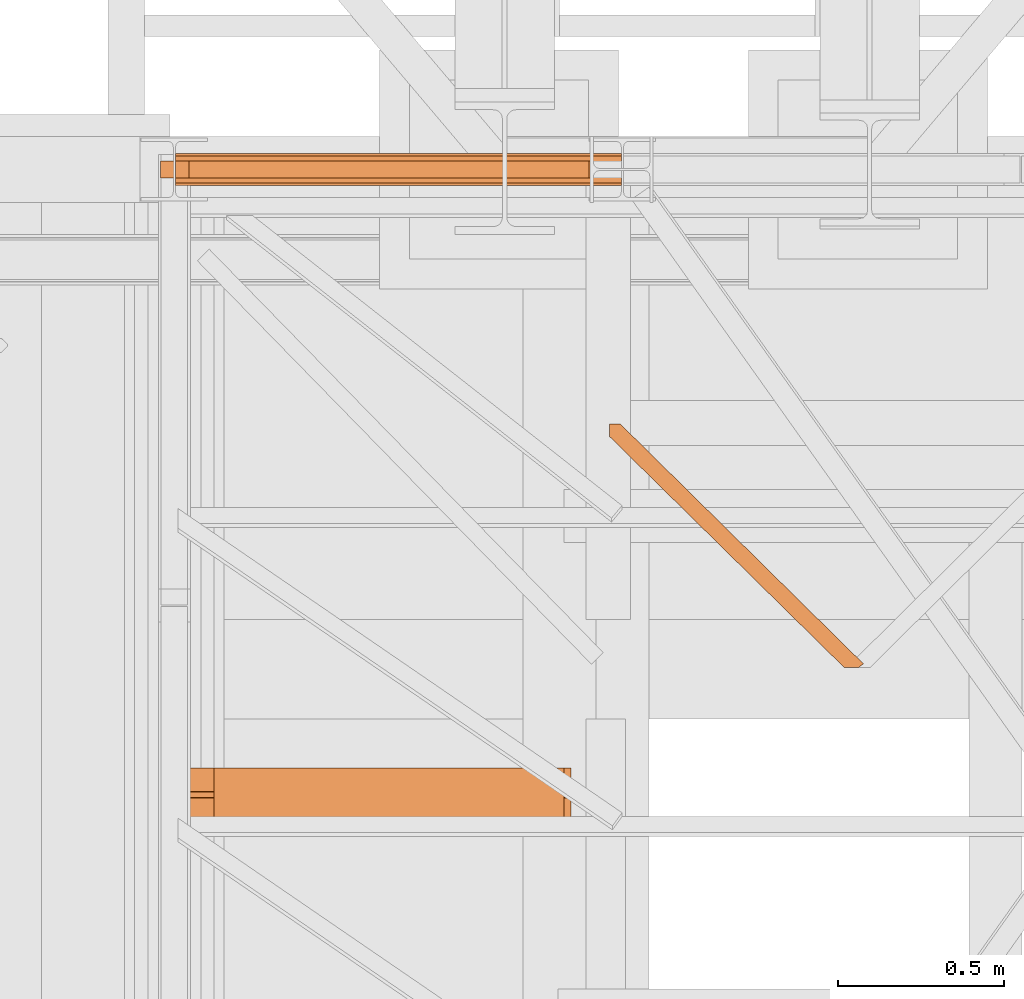
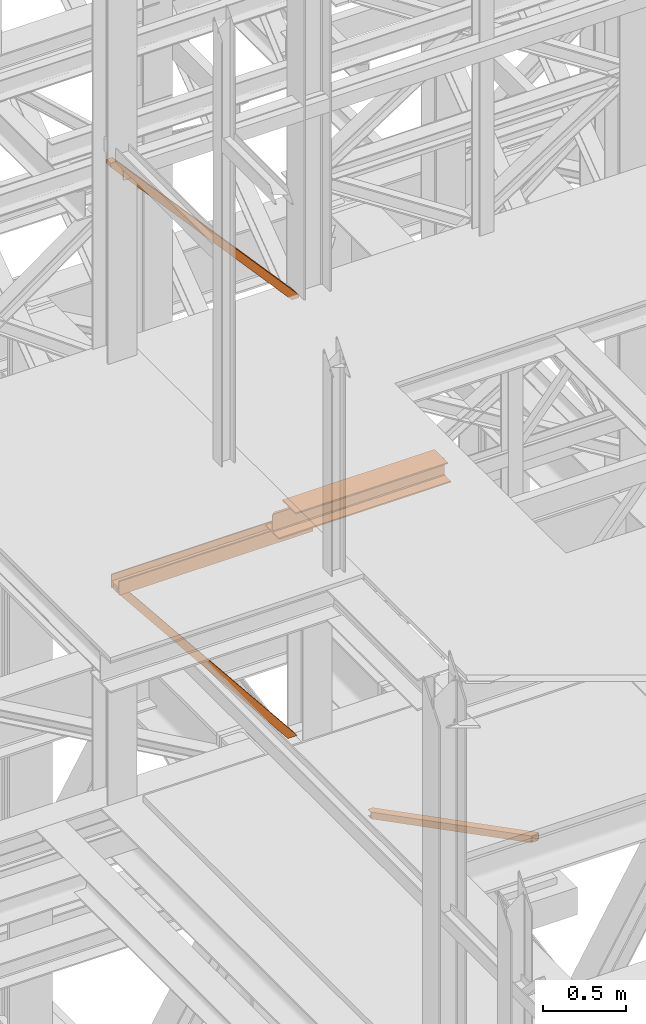
# One storey, part 35 of 208: 5 proxies.
"""IFC2X3 building model written with IfcOpenShell, lengths in millimetres."""

from ifc_helpers import new_model, entity, si_unit, converted_unit, frame, origin, origin_with_axes, place, context, subcontext, project, spatial, faceted_brep, element, save


model = new_model("IFC2X3")

# Units and contexts
model_context = context("Model", 3, precision=1e-05, world=origin())
plan_context = context("Plan", 3, precision=1e-05, world=origin())
body_context = subcontext(model_context, "Body", "Model", "MODEL_VIEW")
ifc_project = project(units=[si_unit("LENGTHUNIT", "METRE", prefix="MILLI"), converted_unit("PLANEANGLEUNIT", "DEGREE", entity("IfcPlaneAngleMeasure", 0.0174532925199433), si_unit("PLANEANGLEUNIT", "RADIAN"), dimensions=[0, 0, 0, 0, 0, 0, 0]), si_unit("AREAUNIT", "SQUARE_METRE"), si_unit("VOLUMEUNIT", "CUBIC_METRE")], contexts=[model_context, plan_context])

# Building, storey
building_placement = place(None, origin())
building = spatial("IfcBuilding", under=ifc_project, at=building_placement, CompositionType="COMPLEX")
storey_placement = place(building_placement, origin_with_axes())
storey = spatial("IfcBuildingStorey", under=building, at=storey_placement, Name="Geschoss", CompositionType="ELEMENT")

# Proxies
proxy_1_placement = place(storey_placement, frame((1156.503995494019, -17287.57439069042, 8484.990002086157), z_axis=(0.0, 0.0, 1.0), x_axis=(1.0, 0.0, 0.0)))
element("IfcBuildingElementProxy", 1, at=proxy_1_placement, inside=storey, context=body_context, shape_type="Brep", body=[
    faceted_brep([(1304.510962990662, 0.01000000000567525, 19.5301319327009), (40.73573083418137, 0.01000000000567525, 1439.925067016873), (40.73573083418137, 50.01000074506374, 1439.925067016873), (1304.510962990664, 50.01000074506374, 19.5301319327009), (1304.510962990664, 50.01000074506374, 19.5301319327009), (40.73573083418137, 50.01000074506374, 1439.925067016873), (0.009999999999990905, 50.01000074506374, 1438.117904338133), (1.300874909247568, 50.01000074506374, 1409.02709546241), (1254.95284377165, 50.0100007450601, 0.01000000000021828), (1304.510962990662, 50.0100007450601, 0.01000000000021828), (1254.95284377165, 50.0100007450601, 0.01000000000021828), (1.300874909247568, 50.01000074506374, 1409.02709546241), (1.300874909245749, 0.01000000000567525, 1409.027095462412), (1254.95284377165, 0.01000000000203727, 0.01000000000021828), (1254.95284377165, 0.01000000000203727, 0.01000000000021828), (1.300874909245749, 0.01000000000567525, 1409.027095462412), (0.009999999999990905, 0.01000000000567525, 1438.117904338133), (40.73573083418137, 0.01000000000567525, 1439.925067016873), (1304.510962990662, 0.01000000000567525, 19.5301319327009), (1304.510962990662, 0.01000000000203727, 0.01000000000021828), (40.73573083418137, 0.01000000000567525, 1439.925067016873), (0.009999999999990905, 0.01000000000567525, 1438.117904338133), (0.009999999999990905, 50.01000074506374, 1438.117904338133), (40.73573083418137, 50.01000074506374, 1439.925067016873), (0.009999999999990905, 50.01000074506374, 1438.117904338133), (0.009999999999990905, 0.01000000000567525, 1438.117904338133), (1.300874909245749, 0.01000000000567525, 1409.027095462412), (1.300874909247568, 50.01000074506374, 1409.02709546241), (1304.510962990662, 50.0100007450601, 0.01000000000021828), (1254.95284377165, 50.0100007450601, 0.01000000000021828), (1254.95284377165, 0.01000000000203727, 0.01000000000021828), (1304.510962990662, 0.01000000000203727, 0.01000000000021828), (1304.510962990664, 50.01000074506374, 19.5301319327009), (1304.510962990662, 50.0100007450601, 0.01000000000021828), (1304.510962990662, 0.01000000000203727, 0.01000000000021828), (1304.510962990662, 0.01000000000567525, 19.5301319327009)], [[[0, 1, 2, 3]], [[4, 5, 6, 7, 8, 9]], [[10, 11, 12, 13]], [[14, 15, 16, 17, 18, 19]], [[20, 21, 22, 23]], [[24, 25, 26, 27]], [[28, 29, 30, 31]], [[32, 33, 34, 35]]], orient=[[False], [False], [False], [False], [False], [False], [False], [False]]),
])
proxy_2_placement = place(storey_placement, frame((1201.504968595722, -17310.57438993344, 6759.989999254943), z_axis=(0.0, 0.0, 1.0), x_axis=(1.0, 0.0, 0.0)))
element("IfcBuildingElementProxy", 2, at=proxy_2_placement, inside=storey, context=body_context, shape_type="Brep", body=[
    faceted_brep([(0.009999999999990905, 88.0099999999984, 0.01000000000021828), (0.009999999999990905, 96.0099999999984, 0.01000000000021828), (0.009999999999990905, 96.0099999999984, 100.0100000000002), (0.009999999999990905, 88.0099999999984, 100.0100000000002), (0.009999999999990905, 88.0099999999984, 52.51000000000022), (0.009999999999990905, 8.0099999999984, 52.51000000000022), (0.009999999999990905, 8.0099999999984, 100.0100000000002), (0.009999999999990905, 0.00999999999839929, 100.0100000000002), (0.009999999999990905, 0.00999999999839929, 0.01000000000021828), (0.009999999999990905, 8.0099999999984, 0.01000000000021828), (0.009999999999990905, 8.0099999999984, 47.51000000000022), (0.009999999999990905, 88.0099999999984, 47.51000000000022), (0.009999999999990905, 96.0099999999984, 0.01000000000021828), (0.009999999999990905, 88.0099999999984, 0.01000000000021828), (1343.509999865888, 88.0099999999984, 0.01000000000021828), (1343.509999865888, 96.0099999999984, 0.01000000000021828), (0.009999999999990905, 96.0099999999984, 100.0100000000002), (0.009999999999990905, 96.0099999999984, 0.01000000000021828), (1343.509999865888, 96.0099999999984, 0.01000000000021828), (1343.509999865888, 96.0099999999984, 100.0100000000002), (0.009999999999990905, 88.0099999999984, 100.0100000000002), (0.009999999999990905, 96.0099999999984, 100.0100000000002), (1343.509999865888, 96.0099999999984, 100.0100000000002), (1343.509999865888, 88.0099999999984, 100.0100000000002), (0.009999999999990905, 88.0099999999984, 52.51000000000022), (0.009999999999990905, 88.0099999999984, 100.0100000000002), (1343.509999865888, 88.0099999999984, 100.0100000000002), (1343.509999865888, 88.0099999999984, 52.51000000000022), (0.009999999999990905, 8.0099999999984, 52.51000000000022), (0.009999999999990905, 88.0099999999984, 52.51000000000022), (1343.509999865888, 88.0099999999984, 52.51000000000022), (1343.509999865888, 8.0099999999984, 52.51000000000022), (0.009999999999990905, 8.0099999999984, 100.0100000000002), (0.009999999999990905, 8.0099999999984, 52.51000000000022), (1343.509999865888, 8.0099999999984, 52.51000000000022), (1343.509999865888, 8.0099999999984, 100.0100000000002), (0.009999999999990905, 0.00999999999839929, 100.0100000000002), (0.009999999999990905, 8.0099999999984, 100.0100000000002), (1343.509999865888, 8.0099999999984, 100.0100000000002), (1343.509999865888, 0.00999999999839929, 100.0100000000002), (0.009999999999990905, 0.00999999999839929, 0.01000000000021828), (0.009999999999990905, 0.00999999999839929, 100.0100000000002), (1343.509999865888, 0.00999999999839929, 100.0100000000002), (1343.509999865888, 0.00999999999839929, 0.01000000000021828), (0.009999999999990905, 8.0099999999984, 0.01000000000021828), (0.009999999999990905, 0.00999999999839929, 0.01000000000021828), (1343.509999865888, 0.00999999999839929, 0.01000000000021828), (1343.509999865888, 8.0099999999984, 0.01000000000021828), (0.009999999999990905, 8.0099999999984, 47.51000000000022), (0.009999999999990905, 8.0099999999984, 0.01000000000021828), (1343.509999865888, 8.0099999999984, 0.01000000000021828), (1343.509999865888, 8.0099999999984, 47.51000000000022), (0.009999999999990905, 88.0099999999984, 47.51000000000022), (0.009999999999990905, 8.0099999999984, 47.51000000000022), (1343.509999865888, 8.0099999999984, 47.51000000000022), (1343.509999865888, 88.0099999999984, 47.51000000000022), (0.009999999999990905, 88.0099999999984, 0.01000000000021828), (0.009999999999990905, 88.0099999999984, 47.51000000000022), (1343.509999865888, 88.0099999999984, 47.51000000000022), (1343.509999865888, 88.0099999999984, 0.01000000000021828), (1343.509999865888, 88.0099999999984, 0.01000000000021828), (1343.509999865888, 88.0099999999984, 47.51000000000022), (1343.509999865888, 8.0099999999984, 47.51000000000022), (1343.509999865888, 8.0099999999984, 0.01000000000021828), (1343.509999865888, 0.00999999999839929, 0.01000000000021828), (1343.509999865888, 0.00999999999839929, 100.0100000000002), (1343.509999865888, 8.0099999999984, 100.0100000000002), (1343.509999865888, 8.0099999999984, 52.51000000000022), (1343.509999865888, 88.0099999999984, 52.51000000000022), (1343.509999865888, 88.0099999999984, 100.0100000000002), (1343.509999865888, 96.0099999999984, 100.0100000000002), (1343.509999865888, 96.0099999999984, 0.01000000000021828)], [[[0, 1, 2, 3, 4, 5, 6, 7, 8, 9, 10, 11]], [[12, 13, 14, 15]], [[16, 17, 18, 19]], [[20, 21, 22, 23]], [[24, 25, 26, 27]], [[28, 29, 30, 31]], [[32, 33, 34, 35]], [[36, 37, 38, 39]], [[40, 41, 42, 43]], [[44, 45, 46, 47]], [[48, 49, 50, 51]], [[52, 53, 54, 55]], [[56, 57, 58, 59]], [[60, 61, 62, 63, 64, 65, 66, 67, 68, 69, 70, 71]]], orient=[[False], [False], [False], [False], [False], [False], [False], [False], [False], [False], [False], [False], [False], [False]]),
])
proxy_3_placement = place(storey_placement, frame((1201.504968595721, -17287.57439069042, 5284.990005364413), z_axis=(0.0, 0.0, 1.0), x_axis=(1.0, 0.0, 0.0)))
element("IfcBuildingElementProxy", 3, at=proxy_3_placement, inside=storey, context=body_context, shape_type="Brep", body=[
    faceted_brep([(1246.759998442829, 50.0100007450601, 0.01000000000112777), (1246.759998442828, 0.01000000000203727, 0.01000000000021828), (40.77580661443676, 0.01000000000567525, 1510.509994121497), (40.77580661443676, 50.01000074506374, 1510.509994121497), (1182.312723265392, 50.0100007450601, 0.01000000000112777), (1246.759998442829, 50.0100007450601, 0.01000000000112777), (40.77580661443676, 50.01000074506374, 1510.509994121497), (0.0100000000009004, 50.01000074506374, 1510.509994121497), (0.0100000000009004, 50.01000074506374, 1481.39055870329), (1182.312723265392, 0.01000000000203727, 0.01000000000112777), (1182.312723265392, 50.0100007450601, 0.01000000000112777), (0.0100000000009004, 50.01000074506374, 1481.39055870329), (0.009999999999990905, 0.01000000000567525, 1481.390558703291), (1246.759998442828, 0.01000000000203727, 0.01000000000021828), (1182.312723265392, 0.01000000000203727, 0.01000000000112777), (0.009999999999990905, 0.01000000000567525, 1481.390558703291), (0.009999999999990905, 0.01000000000567525, 1510.509994121498), (40.77580661443676, 0.01000000000567525, 1510.509994121497), (40.77580661443676, 0.01000000000567525, 1510.509994121497), (0.009999999999990905, 0.01000000000567525, 1510.509994121498), (0.0100000000009004, 50.01000074506374, 1510.509994121497), (40.77580661443676, 50.01000074506374, 1510.509994121497), (0.0100000000009004, 50.01000074506374, 1510.509994121497), (0.009999999999990905, 0.01000000000567525, 1510.509994121498), (0.009999999999990905, 0.01000000000567525, 1481.390558703291), (0.0100000000009004, 50.01000074506374, 1481.39055870329), (1246.759998442829, 50.0100007450601, 0.01000000000112777), (1182.312723265392, 50.0100007450601, 0.01000000000112777), (1182.312723265392, 0.01000000000203727, 0.01000000000112777), (1246.759998442828, 0.01000000000203727, 0.01000000000021828)], [[[0, 1, 2, 3]], [[4, 5, 6, 7, 8]], [[9, 10, 11, 12]], [[13, 14, 15, 16, 17]], [[18, 19, 20, 21]], [[22, 23, 24, 25]], [[26, 27, 28, 29]]], orient=[[False], [False], [False], [False], [False], [False], [False]]),
])
proxy_4_placement = place(storey_placement, frame((2509.054968290991, -18763.0743901279, 5124.989999999998), z_axis=(0.0, 0.0, 1.0), x_axis=(1.0, 0.0, 0.0)))
element("IfcBuildingElementProxy", 4, at=proxy_4_placement, inside=storey, context=body_context, shape_type="Brep", body=[
    faceted_brep([(707.2343869634424, 0.00999999999839929, 50.01000000000022), (707.2343869634424, 0.00999999999839929, 0.01000000000021828), (0.01000000000021828, 696.0901851389281, 0.01000000000021828), (0.01000000000021828, 696.0901851389281, 50.01000000000022), (707.2343869634424, 0.00999999999839929, 0.01000000000021828), (750.8895703656499, 0.00999999999839929, 0.01000000000021828), (765.4815248505074, 10.86988655012465, 0.01000000000021828), (33.18012058976092, 733.210000142677, 0.009999999999308784), (0.01000000000112777, 733.210000142677, 0.01000000000021828), (0.01000000000021828, 696.0901851389281, 0.01000000000021828), (765.4815248505074, 10.86988655012465, 0.01000000000021828), (765.4815248505074, 10.86988655012465, 50.01000000000022), (33.18012058976092, 733.210000142677, 50.00999999999931), (33.18012058976092, 733.210000142677, 0.009999999999308784), (765.4815248505074, 10.86988655012465, 50.01000000000022), (750.8895703656499, 0.00999999999839929, 50.01000000000022), (707.2343869634424, 0.00999999999839929, 50.01000000000022), (0.01000000000021828, 696.0901851389281, 50.01000000000022), (0.01000000000203727, 733.210000142677, 50.01000000000022), (33.18012058976092, 733.210000142677, 50.00999999999931), (750.8895703656499, 0.00999999999839929, 0.01000000000021828), (750.8895703656499, 0.00999999999839929, 4.010000000000218), (762.2726717624464, 8.481736249315873, 4.010000000000218), (762.2726717624464, 8.481736249315873, 46.01000000000022), (750.8895703656499, 0.00999999999839929, 46.01000000000022), (750.8895703656499, 0.00999999999839929, 50.01000000000022), (765.4815248505074, 10.86988655012465, 50.01000000000022), (765.4815248505074, 10.86988655012465, 0.01000000000021828), (712.7238131500808, 0.00999999999839929, 4.010000000000218), (712.7238131500808, 0.00999999999839929, 46.01000000000022), (0.01000000000203727, 701.8385537428767, 46.01000000000022), (0.01000000000203727, 701.8385537428767, 4.010000000000218), (750.8895703656499, 0.00999999999839929, 4.010000000000218), (712.7238131500808, 0.00999999999839929, 4.010000000000218), (0.01000000000203727, 701.8385537428767, 4.010000000000218), (0.01000000000203727, 733.210000142677, 4.010000000000218), (27.69069440312251, 733.210000142677, 4.010000000000218), (762.2726717624464, 8.481736249315873, 4.010000000000218), (762.2726717624464, 8.481736249315873, 4.010000000000218), (27.69069440312251, 733.210000142677, 4.010000000000218), (27.69069440312251, 733.210000142677, 46.01000000000022), (762.2726717624464, 8.481736249315873, 46.01000000000022), (762.2726717624464, 8.481736249315873, 46.01000000000022), (27.69069440312251, 733.210000142677, 46.01000000000022), (0.01000000000112777, 733.210000142677, 46.01000000000022), (0.01000000000203727, 701.8385537428767, 46.01000000000022), (712.7238131500808, 0.00999999999839929, 46.01000000000022), (750.8895703656499, 0.00999999999839929, 46.01000000000022), (0.01000000000203727, 733.210000142677, 4.010000000000218), (0.01000000000112777, 733.210000142677, 0.01000000000021828), (33.18012058976092, 733.210000142677, 0.009999999999308784), (33.18012058976092, 733.210000142677, 50.00999999999931), (0.01000000000203727, 733.210000142677, 50.01000000000022), (0.01000000000112777, 733.210000142677, 46.01000000000022), (27.69069440312251, 733.210000142677, 46.01000000000022), (27.69069440312251, 733.210000142677, 4.010000000000218), (0.01000000000021828, 696.0901851389281, 50.01000000000022), (0.01000000000021828, 696.0901851389281, 0.01000000000021828), (0.01000000000112777, 733.210000142677, 0.01000000000021828), (0.01000000000203727, 733.210000142677, 4.010000000000218), (0.01000000000203727, 701.8385537428767, 4.010000000000218), (0.01000000000203727, 701.8385537428767, 46.01000000000022), (0.01000000000112777, 733.210000142677, 46.01000000000022), (0.01000000000203727, 733.210000142677, 50.01000000000022), (707.2343869634424, 0.00999999999839929, 0.01000000000021828), (707.2343869634424, 0.00999999999839929, 50.01000000000022), (750.8895703656499, 0.00999999999839929, 50.01000000000022), (750.8895703656499, 0.00999999999839929, 46.01000000000022), (712.7238131500808, 0.00999999999839929, 46.01000000000022), (712.7238131500808, 0.00999999999839929, 4.010000000000218), (750.8895703656499, 0.00999999999839929, 4.010000000000218), (750.8895703656499, 0.00999999999839929, 0.01000000000021828)], [[[0, 1, 2, 3]], [[4, 5, 6, 7, 8, 9]], [[10, 11, 12, 13]], [[14, 15, 16, 17, 18, 19]], [[20, 21, 22, 23, 24, 25, 26, 27]], [[28, 29, 30, 31]], [[32, 33, 34, 35, 36, 37]], [[38, 39, 40, 41]], [[42, 43, 44, 45, 46, 47]], [[48, 49, 50, 51, 52, 53, 54, 55]], [[56, 57, 58, 59, 60, 61, 62, 63]], [[64, 65, 66, 67, 68, 69, 70, 71]]], orient=[[False], [False], [False], [False], [False], [False], [False], [False], [False], [False], [False], [False]]),
])
proxy_5_placement = place(storey_placement, frame((1202.004968677677, -19226.85030250341, 8332.989992072577), z_axis=(0.0, 0.0, 1.0), x_axis=(1.0, 0.0, 0.0)))
element("IfcBuildingElementProxy", 5, at=proxy_5_placement, inside=storey, context=body_context, shape_type="Brep", body=[
    faceted_brep([(0.009999999999990905, 83.01000568851669, 119.0100101923945), (0.009999999999990905, 77.01000563636262, 119.0100101923945), (0.009999999999990905, 77.01000563636262, 24.01000393390677), (0.009999999999990905, 75.45621545821268, 16.24682677745841), (0.009999999999990905, 69.77318079978068, 10.5637921190264), (0.009999999999990905, 62.01000457465489, 9.010003337860326), (0.009999999999990905, 0.00999999999839929, 9.010003337860326), (0.009999999999990905, 0.00999999999839929, 0.01000000000021828), (0.009999999999990905, 160.0100113248809, 0.01000000000021828), (0.009999999999990905, 160.0100113248809, 9.010003337860326), (0.009999999999990905, 98.01000675022442, 9.010003337860326), (0.009999999999990905, 90.24683052509863, 10.5637921190264), (0.009999999999990905, 84.56379586666662, 16.24682677745841), (0.009999999999990905, 83.01000568851669, 24.01000393390677), (116.26000461936, 0.00999999999839929, 152.0100100135805), (116.26000461936, 160.0100113248809, 152.0100100135805), (1170.010000000002, 160.0100113248809, 152.0100100135805), (1170.010000000002, 0.00999999999839929, 152.0100100135805), (116.26000461936, 160.0100113248809, 152.0100100135805), (116.26000461936, 160.0100113248809, 143.0100066757204), (1170.010000000002, 160.0100113248809, 143.0100066757204), (1170.010000000002, 160.0100113248809, 152.0100100135805), (116.26000461936, 160.0100113248809, 143.0100066757204), (116.26000461936, 98.01000675022442, 143.0100066757204), (1170.010000000002, 98.01000675022442, 143.0100066757204), (1170.010000000002, 160.0100113248809, 143.0100066757204), (116.26000461936, 98.01000675022442, 143.0100066757204), (116.26000461936, 90.24683052509863, 141.4562178945544), (1170.010000000002, 90.24683052509863, 141.4562178945544), (1170.010000000002, 98.01000675022442, 143.0100066757204), (116.26000461936, 90.24683052509863, 141.4562178945544), (116.26000461936, 88.80062067717154, 140.0100080466273), (21.01000157952308, 88.80062067717154, 140.0100080466273), (10.14155560940412, 86.62531936377127, 137.834706733227), (8.08003259492375, 84.56379586666662, 135.7731832361224), (1182.939968984598, 84.56379586666662, 135.7731832361224), (1180.87844597012, 86.62531936377127, 137.834706733227), (1170.010000000002, 88.80062067717154, 140.0100080466273), (1170.010000000002, 90.24683052509863, 141.4562178945544), (8.08003259492375, 84.56379586666662, 135.7731832361224), (2.185305970013133, 83.38397287827684, 129.87845523119), (1.811338905192997, 83.01000568851669, 128.0100098049643), (1189.208662674331, 83.01000568851669, 128.0100098049643), (1188.834695609512, 83.38397287827684, 129.87845523119), (1182.939968984598, 84.56379586666662, 135.7731832361224), (0.009999999999990905, 83.01000568851669, 24.01000393390677), (1191.010001579525, 83.01000568851669, 24.01000393390677), (1191.010001579525, 83.01000568851669, 119.0100101923945), (1189.208662674331, 83.01000568851669, 128.0100098049643), (1.811338905192997, 83.01000568851669, 128.0100098049643), (0.009999999999990905, 83.01000568851669, 119.0100101923945), (0.009999999999990905, 84.56379586666662, 16.24682677745841), (1191.010001579525, 84.56379586666662, 16.24682677745841), (1191.010001579525, 83.01000568851669, 24.01000393390677), (0.009999999999990905, 83.01000568851669, 24.01000393390677), (0.009999999999990905, 90.24683052509863, 10.5637921190264), (1191.010001579525, 90.24683052509863, 10.5637921190264), (1191.010001579525, 84.56379586666662, 16.24682677745841), (0.009999999999990905, 84.56379586666662, 16.24682677745841), (0.009999999999990905, 98.01000675022442, 9.010003337860326), (1191.010001579525, 98.01000675022442, 9.010003337860326), (1191.010001579525, 90.24683052509863, 10.5637921190264), (0.009999999999990905, 90.24683052509863, 10.5637921190264), (0.009999999999990905, 160.0100113248809, 9.010003337860326), (1191.010001579525, 160.0100113248809, 9.010003337860326), (1191.010001579525, 98.01000675022442, 9.010003337860326), (0.009999999999990905, 98.01000675022442, 9.010003337860326), (0.009999999999990905, 160.0100113248809, 0.01000000000021828), (1191.010001579525, 160.0100113248809, 0.01000000000021828), (1191.010001579525, 160.0100113248809, 9.010003337860326), (0.009999999999990905, 160.0100113248809, 9.010003337860326), (0.009999999999990905, 0.00999999999839929, 0.01000000000021828), (1191.010001579527, 0.00999999999839929, 0.01000000000021828), (1191.010001579525, 160.0100113248809, 0.01000000000021828), (0.009999999999990905, 160.0100113248809, 0.01000000000021828), (0.009999999999990905, 0.00999999999839929, 9.010003337860326), (1191.010001579525, 0.00999999999839929, 9.010003337860326), (1191.010001579527, 0.00999999999839929, 0.01000000000021828), (0.009999999999990905, 0.00999999999839929, 0.01000000000021828), (0.009999999999990905, 62.01000457465489, 9.010003337860326), (1191.010001579525, 62.01000457465489, 9.010003337860326), (1191.010001579525, 0.00999999999839929, 9.010003337860326), (0.009999999999990905, 0.00999999999839929, 9.010003337860326), (0.009999999999990905, 69.77318079978068, 10.5637921190264), (1191.010001579525, 69.77318079978068, 10.5637921190264), (1191.010001579525, 62.01000457465489, 9.010003337860326), (0.009999999999990905, 62.01000457465489, 9.010003337860326), (0.009999999999990905, 75.45621545821268, 16.24682677745841), (1191.010001579525, 75.45621545821268, 16.24682677745841), (1191.010001579525, 69.77318079978068, 10.5637921190264), (0.009999999999990905, 69.77318079978068, 10.5637921190264), (0.009999999999990905, 77.01000563636262, 24.01000393390677), (1191.010001579525, 77.01000563636262, 24.01000393390677), (1191.010001579525, 75.45621545821268, 16.24682677745841), (0.009999999999990905, 75.45621545821268, 16.24682677745841), (0.009999999999990905, 77.01000563636262, 119.0100101923945), (1.811338905192997, 77.01000563636262, 128.0100098049643), (1189.208662674331, 77.01000563636262, 128.0100098049643), (1191.010001579525, 77.01000563636262, 119.0100101923945), (1191.010001579525, 77.01000563636262, 24.01000393390677), (0.009999999999990905, 77.01000563636262, 24.01000393390677), (1.811338905192997, 77.01000563636262, 128.0100098049643), (2.185305970013133, 76.63603844660247, 129.87845523119), (8.08003259492375, 75.45621545821268, 135.7731832361224), (1182.939968984598, 75.45621545821268, 135.7731832361224), (1188.834695609512, 76.63603844660247, 129.87845523119), (1189.208662674331, 77.01000563636262, 128.0100098049643), (8.08003259492375, 75.45621545821268, 135.7731832361224), (10.14155560940503, 73.39469196110804, 137.834706733227), (21.01000157952308, 71.21939064770777, 140.0100080466273), (116.26000461936, 71.21939064770777, 140.0100080466273), (116.26000461936, 69.77318079978068, 141.4562178945544), (1170.010000000002, 69.77318079978068, 141.4562178945544), (1170.010000000002, 71.21939064770777, 140.0100080466273), (1180.87844597012, 73.39469196110804, 137.834706733227), (1182.939968984598, 75.45621545821268, 135.7731832361224), (116.26000461936, 69.77318079978068, 141.4562178945544), (116.26000461936, 62.01000457465489, 143.0100066757204), (1170.010000000002, 62.01000457465489, 143.0100066757204), (1170.010000000002, 69.77318079978068, 141.4562178945544), (116.26000461936, 62.01000457465489, 143.0100066757204), (116.26000461936, 0.00999999999839929, 143.0100066757204), (1170.010000000002, 0.00999999999839929, 143.0100066757204), (1170.010000000002, 62.01000457465489, 143.0100066757204), (116.26000461936, 0.00999999999839929, 143.0100066757204), (116.26000461936, 0.00999999999839929, 152.0100100135805), (1170.010000000002, 0.00999999999839929, 152.0100100135805), (1170.010000000002, 0.00999999999839929, 143.0100066757204), (1191.010001579525, 77.01000563636262, 119.0100101923945), (1191.010001579525, 83.01000568851669, 119.0100101923945), (1191.010001579525, 83.01000568851669, 24.01000393390677), (1191.010001579525, 84.56379586666662, 16.24682677745841), (1191.010001579525, 90.24683052509863, 10.5637921190264), (1191.010001579525, 98.01000675022442, 9.010003337860326), (1191.010001579525, 160.0100113248809, 9.010003337860326), (1191.010001579525, 160.0100113248809, 0.01000000000021828), (1191.010001579527, 0.00999999999839929, 0.01000000000021828), (1191.010001579525, 0.00999999999839929, 9.010003337860326), (1191.010001579525, 62.01000457465489, 9.010003337860326), (1191.010001579525, 69.77318079978068, 10.5637921190264), (1191.010001579525, 75.45621545821268, 16.24682677745841), (1191.010001579525, 77.01000563636262, 24.01000393390677), (1191.010001579525, 83.01000568851669, 119.0100101923945), (1191.010001579525, 77.01000563636262, 119.0100101923945), (1189.208662674331, 77.01000563636262, 128.0100098049643), (1188.834695609512, 76.63603844660247, 129.87845523119), (1188.834695609512, 83.38397287827684, 129.87845523119), (1189.208662674331, 83.01000568851669, 128.0100098049643), (1188.834695609512, 83.38397287827684, 129.87845523119), (1188.834695609512, 76.63603844660247, 129.87845523119), (1182.939968984598, 75.45621545821268, 135.7731832361224), (1180.87844597012, 73.39469196110804, 137.834706733227), (1180.87844597012, 86.62531936377127, 137.834706733227), (1182.939968984598, 84.56379586666662, 135.7731832361224), (1180.87844597012, 86.62531936377127, 137.834706733227), (1180.87844597012, 73.39469196110804, 137.834706733227), (1170.010000000002, 71.21939064770777, 140.0100080466273), (1170.010000000002, 88.80062067717154, 140.0100080466273), (1170.010000000002, 88.80062067717154, 140.0100080466273), (1170.010000000002, 71.21939064770777, 140.0100080466273), (1170.010000000002, 69.77318079978068, 141.4562178945544), (1170.010000000002, 62.01000457465489, 143.0100066757204), (1170.010000000002, 0.00999999999839929, 143.0100066757204), (1170.010000000002, 0.00999999999839929, 152.0100100135805), (1170.010000000002, 160.0100113248809, 152.0100100135805), (1170.010000000002, 160.0100113248809, 143.0100066757204), (1170.010000000002, 98.01000675022442, 143.0100066757204), (1170.010000000002, 90.24683052509863, 141.4562178945544), (0.009999999999990905, 77.01000563636262, 119.0100101923945), (0.009999999999990905, 83.01000568851669, 119.0100101923945), (1.811338905192997, 83.01000568851669, 128.0100098049643), (2.185305970013133, 83.38397287827684, 129.87845523119), (2.185305970013133, 76.63603844660247, 129.87845523119), (1.811338905192997, 77.01000563636262, 128.0100098049643), (2.185305970013133, 76.63603844660247, 129.87845523119), (2.185305970013133, 83.38397287827684, 129.87845523119), (8.08003259492375, 84.56379586666662, 135.7731832361224), (10.14155560940412, 86.62531936377127, 137.834706733227), (10.14155560940503, 73.39469196110804, 137.834706733227), (8.08003259492375, 75.45621545821268, 135.7731832361224), (10.14155560940503, 73.39469196110804, 137.834706733227), (10.14155560940412, 86.62531936377127, 137.834706733227), (21.01000157952308, 88.80062067717154, 140.0100080466273), (21.01000157952308, 71.21939064770777, 140.0100080466273), (21.01000157952308, 71.21939064770777, 140.0100080466273), (21.01000157952308, 88.80062067717154, 140.0100080466273), (116.26000461936, 88.80062067717154, 140.0100080466273), (116.26000461936, 71.21939064770777, 140.0100080466273), (116.26000461936, 71.21939064770777, 140.0100080466273), (116.26000461936, 88.80062067717154, 140.0100080466273), (116.26000461936, 90.24683052509863, 141.4562178945544), (116.26000461936, 98.01000675022442, 143.0100066757204), (116.26000461936, 160.0100113248809, 143.0100066757204), (116.26000461936, 160.0100113248809, 152.0100100135805), (116.26000461936, 0.00999999999839929, 152.0100100135805), (116.26000461936, 0.00999999999839929, 143.0100066757204), (116.26000461936, 62.01000457465489, 143.0100066757204), (116.26000461936, 69.77318079978068, 141.4562178945544)], [[[0, 1, 2, 3, 4, 5, 6, 7, 8, 9, 10, 11, 12, 13]], [[14, 15, 16, 17]], [[18, 19, 20, 21]], [[22, 23, 24, 25]], [[26, 27, 28, 29]], [[30, 31, 32, 33, 34, 35, 36, 37, 38]], [[39, 40, 41, 42, 43, 44]], [[45, 46, 47, 48, 49, 50]], [[51, 52, 53, 54]], [[55, 56, 57, 58]], [[59, 60, 61, 62]], [[63, 64, 65, 66]], [[67, 68, 69, 70]], [[71, 72, 73, 74]], [[75, 76, 77, 78]], [[79, 80, 81, 82]], [[83, 84, 85, 86]], [[87, 88, 89, 90]], [[91, 92, 93, 94]], [[95, 96, 97, 98, 99, 100]], [[101, 102, 103, 104, 105, 106]], [[107, 108, 109, 110, 111, 112, 113, 114, 115]], [[116, 117, 118, 119]], [[120, 121, 122, 123]], [[124, 125, 126, 127]], [[128, 129, 130, 131, 132, 133, 134, 135, 136, 137, 138, 139, 140, 141]], [[142, 143, 144, 145, 146, 147]], [[148, 149, 150, 151, 152, 153]], [[154, 155, 156, 157]], [[158, 159, 160, 161, 162, 163, 164, 165, 166, 167]], [[168, 169, 170, 171, 172, 173]], [[174, 175, 176, 177, 178, 179]], [[180, 181, 182, 183]], [[184, 185, 186, 187]], [[188, 189, 190, 191, 192, 193, 194, 195, 196, 197]]], orient=[[False], [False], [False], [False], [False], [False], [False], [False], [False], [False], [False], [False], [False], [False], [False], [False], [False], [False], [False], [False], [False], [False], [False], [False], [False], [False], [False], [False], [False], [False], [False], [False], [False], [False], [False]]),
])

save(model, "model.ifc")
